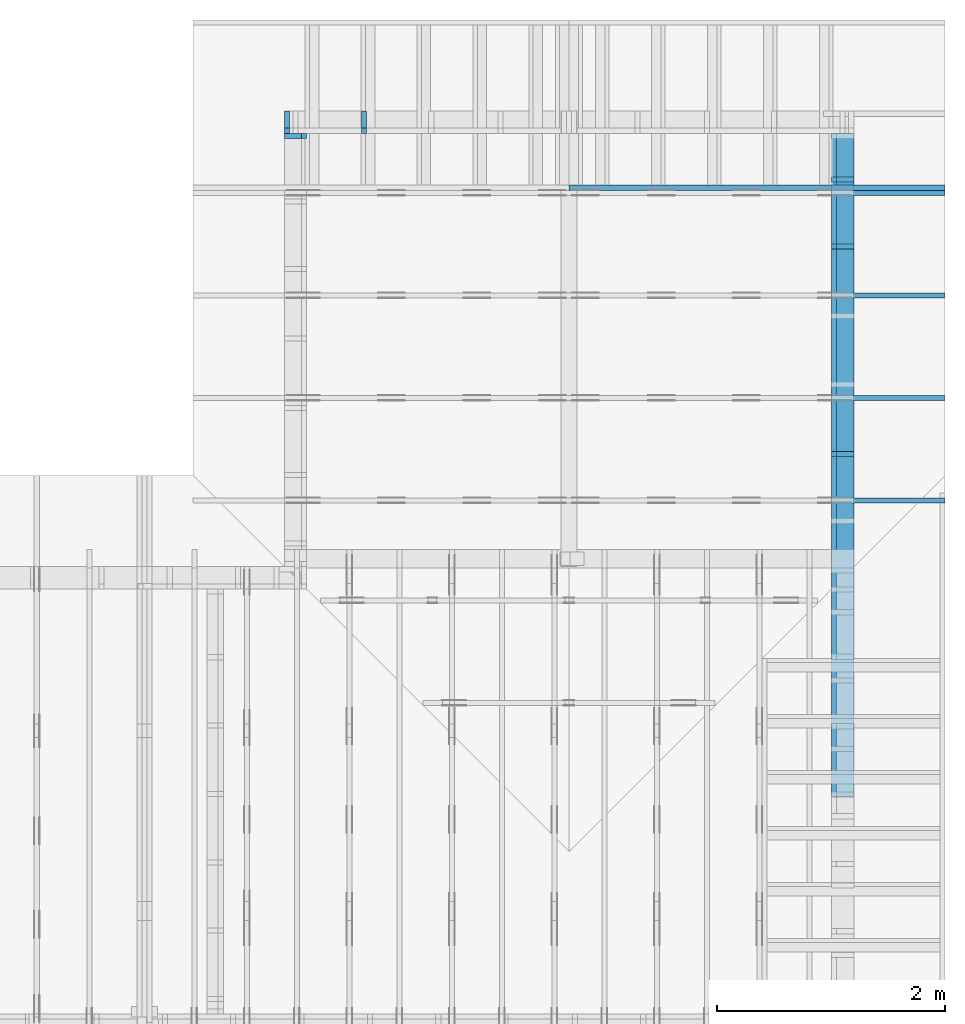
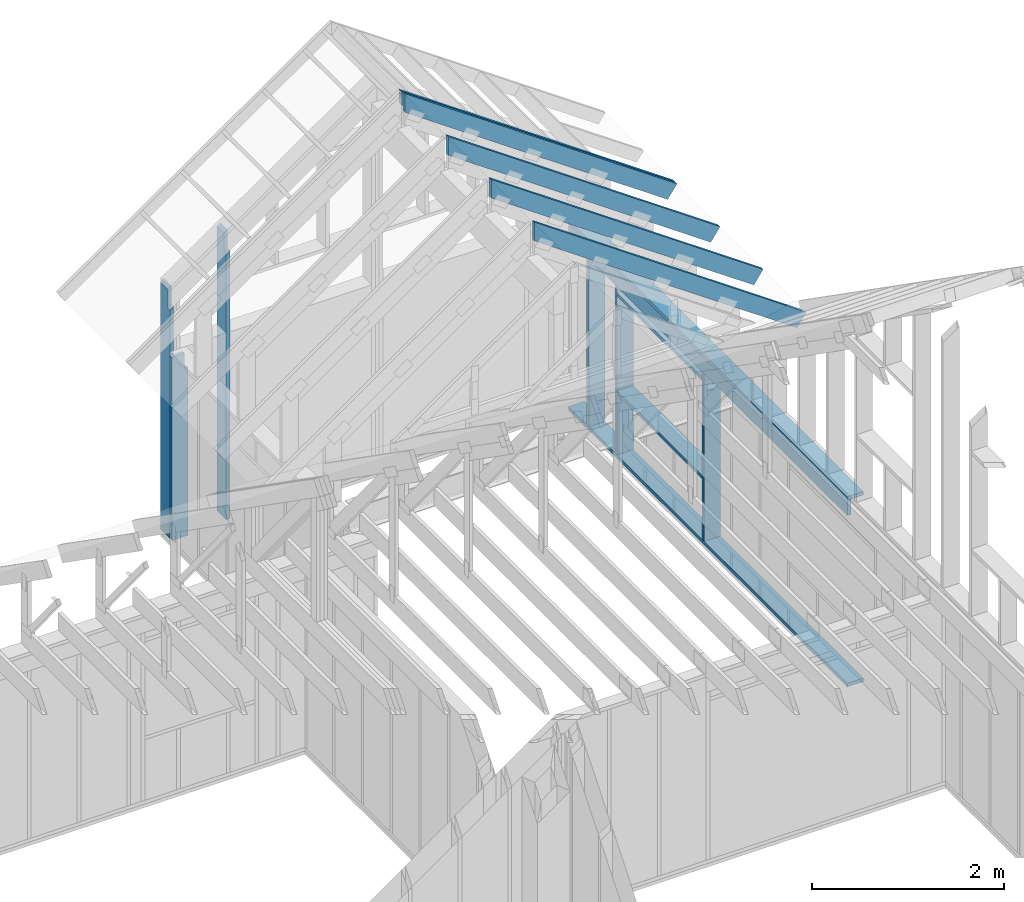
# One storey, part 33 of 70: 16 members, 8 elements without a shape of their own.
"""IFC2X3 building model written with IfcOpenShell, lengths in millimetres."""

from ifc_helpers import new_model, si_unit, frame, origin, origin_with_axes, origin_2d, place, context, project, spatial, faceted_brep, element, aggregate, save


model = new_model("IFC2X3")

# Units and contexts
model_context = context("Model", 3, precision=1e-05, world=origin())
plan_context = context("Plan", 2, precision=1e-05, world=origin_2d())
ifc_project = project(units=[si_unit("LENGTHUNIT", "METRE", prefix="MILLI"), si_unit("AREAUNIT", "SQUARE_METRE"), si_unit("VOLUMEUNIT", "CUBIC_METRE"), si_unit("SOLIDANGLEUNIT", "STERADIAN"), si_unit("PLANEANGLEUNIT", "RADIAN"), si_unit("MASSUNIT", "GRAM"), si_unit("TIMEUNIT", "SECOND"), si_unit("THERMODYNAMICTEMPERATUREUNIT", "DEGREE_CELSIUS"), si_unit("LUMINOUSINTENSITYUNIT", "LUMEN")], contexts=[model_context, plan_context])

# Site, building, storey
site_placement = place(None, origin_with_axes())
site = spatial("IfcSite", under=ifc_project, at=site_placement, CompositionType="ELEMENT")
building_placement = place(site_placement, origin_with_axes())
building = spatial("IfcBuilding", under=site, at=building_placement, Name="Layout 1", CompositionType="ELEMENT")
storey_placement = place(building_placement, origin_with_axes())
storey = spatial("IfcBuildingStorey", under=building, at=storey_placement, Name="Storey 1", CompositionType="ELEMENT", Elevation=0.0)

# Assembly, member
assembly_1_placement = place(storey_placement, frame((7000.0, 11805.0, -2470.0), z_axis=(-1.0, 1.836909530733566e-16, 6.123031769111886e-17), x_axis=(-1.836909530733566e-16, -1.0, 0.0)))
assembly_1 = element("IfcElementAssembly", 1, at=assembly_1_placement, inside=storey, Name="VE1", AssemblyPlace="FACTORY", PredefinedType="NOTDEFINED")
member_1_placement = place(assembly_1_placement, frame((45.00000000186265, 90.00000000000045, -195.00000000000003), z_axis=(0.0, 0.0, 1.0), x_axis=(6.123031769111886e-17, 1.0, 0.0)))
member_1 = element("IfcMember", 2, at=member_1_placement, Name="S11", context=model_context, shape_type="Brep", body=[
    faceted_brep([(2139.999999998137, 45.00000000170723, 2.842170943040401e-14), (2139.999999998137, 45.00000000170723, 45.00000000000003), (2139.999999998137, 1.7072281366381503e-09, 45.00000000000003), (2139.999999998137, 1.7072281366381503e-09, 2.842170943040401e-14), (2139.999999998137, 45.00000000170723, 45.00000000000029), (2334.9999999999995, 45.00000000170723, 45.00000000000031), (2334.9999999999995, 1.7072281366381503e-09, 45.00000000000031), (2139.999999998137, 1.7072281366381503e-09, 45.00000000000029), (-1.0655730319954681e-46, 45.000000001862794, 2.842170943040401e-14), (-7.310846018882921e-31, 45.00000000186278, 195.00000000000003), (2334.9999999999995, 45.00000000186264, 195.00000000000003), (2334.9999999999995, 45.000000001862645, 45.00000000000003), (2139.999999998137, 45.00000000186266, 45.00000000000003), (2139.999999998137, 45.00000000186267, 2.8421709430404e-14), (0.0, 45.00000000000001, 2.842170943040401e-14), (2139.999999998137, 45.00000000000001, 2.904874691481646e-13), (2139.999999998137, 1.7072281366381503e-09, 2.904874691481646e-13), (0.0, 1.7072281366381503e-09, 2.842170943040401e-14), (0.0, 0.0, 0.0), (1.193991194976818e-14, -1.4621692037765842e-30, 195.00000000000003), (1.745064054196888e-14, 45.000000000000014, 195.00000000000003), (5.510728592200699e-15, 45.000000000000014, -3.37423662409981e-31), (2334.9999999999995, 1.7068019736270201e-09, 45.00000000000003), (2334.9999999999995, 1.7068111581746738e-09, 195.00000000000003), (2.1932538056648764e-30, 1.7072400765501e-09, 195.00000000000003), (3.1967190959864043e-46, 1.7072281366381503e-09, 2.842170943040401e-14), (2139.999999998137, 1.7068350379985737e-09, 2.842170943040403e-14), (2139.999999998137, 1.7068377933628698e-09, 45.00000000000003), (2334.9999999999995, 45.0000000018628, 45.00000000000003), (2334.9999999999995, 45.0000000018628, 195.00000000000003), (2334.9999999999995, 1.8628014686328243e-09, 195.00000000000003), (2334.9999999999995, 1.8628014686328243e-09, 45.00000000000003), (2334.9999999999995, 45.000000001862794, 195.00000000000003), (0.0, 45.000000001862794, 195.00000000000003), (0.0, 7.105427357601002e-15, 195.00000000000003), (2334.9999999999995, 7.105427357601002e-15, 195.00000000000003)], [[[0, 1, 2, 3]], [[4, 5, 6, 7]], [[8, 9, 10, 11, 12, 13]], [[14, 15, 16, 17]], [[18, 19, 20, 21]], [[22, 23, 24, 25, 26, 27]], [[28, 29, 30, 31]], [[32, 33, 34, 35]]]),
])
aggregate(assembly_1, [member_1])

# Assembly, members
assembly_2_placement = place(storey_placement, frame((12000.0, 0.0, -2470.0), z_axis=(1.0, -6.123031769111886e-17, 6.123031769111886e-17), x_axis=(6.123031769111886e-17, 1.0, 0.0)))
assembly_2 = element("IfcElementAssembly", 3, at=assembly_2_placement, inside=storey, Name="VE5", AssemblyPlace="FACTORY", PredefinedType="NOTDEFINED")
member_2_placement = place(assembly_2_placement, frame((5980.0, 2425.0, -195.0), z_axis=(0.0, 0.0, 1.0), x_axis=(1.0, 0.0, 0.0)))
member_2 = element("IfcMember", 4, at=member_2_placement, Name="P4", context=model_context, shape_type="Brep", body=[
    faceted_brep([(5825.0, 45.0, 195.0), (0.0, 45.0, 195.0), (0.0, 0.0, 195.0), (5825.0, 0.0, 195.0), (0.0, 45.0, 0.0), (5825.0, 45.0, 7.133332011015348e-13), (5825.0, 0.0, 7.133332011015348e-13), (0.0, 0.0, 0.0), (0.0, 0.0, 0.0), (1.1939911949768178e-14, -1.462169203776584e-30, 195.0), (1.7450640541968876e-14, 45.0, 195.0), (5.510728592200698e-15, 45.0, -3.3742366240998092e-31), (5825.0, -1.0699998016523021e-12, 6.551642778460463e-29), (5825.0, -1.058059889702534e-12, 195.0), (2.193253805664876e-30, 1.1939911949768178e-14, 195.0), (0.0, 0.0, 0.0), (5825.0, 45.0, 0.0), (5825.0, 45.0, 195.0), (5825.0, 0.0, 195.0), (5825.0, 0.0, 0.0), (0.0, 45.0, 0.0), (-7.31084601888292e-31, 44.999999999999986, 195.0), (5825.0, 44.99999999999963, 195.0), (5825.0, 44.999999999999645, -2.1693674893577825e-29)], [[[0, 1, 2, 3]], [[4, 5, 6, 7]], [[8, 9, 10, 11]], [[12, 13, 14, 15]], [[16, 17, 18, 19]], [[20, 21, 22, 23]]]),
])
member_3_placement = place(assembly_2_placement, frame((11805.0, 90.0, -195.0), z_axis=(0.0, 0.0, 1.0), x_axis=(-1.0, 1.2246063538223773e-16, 0.0)))
member_3 = element("IfcMember", 5, at=member_3_placement, Name="P4", context=model_context, shape_type="Brep", body=[
    faceted_brep([(5825.0, 45.00000000000072, 195.0), (0.0, 45.00000000000072, 195.0), (0.0, 0.0, 195.0), (5825.0, 0.0, 195.0), (0.0, 45.00000000000072, 0.0), (5825.0, 45.00000000000072, 7.133332011015348e-13), (5825.0, 0.0, 7.133332011015348e-13), (0.0, 0.0, 0.0), (0.0, 0.0, 0.0), (1.1939911949768178e-14, -1.462169203776584e-30, 195.0), (1.7450640541968876e-14, 45.00000000000001, 195.0), (5.5107285922006985e-15, 45.00000000000001, -3.3742366240998097e-31), (5825.0, -1.0699998016523021e-12, 1.0902318522831229e-28), (5825.0, -1.058059889702534e-12, 195.0), (2.193253805664876e-30, 1.1939911949768178e-14, 195.0), (0.0, 0.0, 0.0), (5825.0, 45.00000000000072, 0.0), (5825.0, 45.00000000000072, 195.0), (5825.0, 7.105427357601002e-13, 195.0), (5825.0, 7.105427357601002e-13, 0.0), (0.0, 45.00000000000001, 0.0), (1.5777218104420236e-30, 44.99999999999999, 195.0), (5825.0, 45.00000000000093, 195.0), (5825.0, 45.000000000000945, 1.3805065841367707e-29)], [[[0, 1, 2, 3]], [[4, 5, 6, 7]], [[8, 9, 10, 11]], [[12, 13, 14, 15]], [[16, 17, 18, 19]], [[20, 21, 22, 23]]]),
])
member_4_placement = place(assembly_2_placement, frame((5980.0, 2230.0, -195.0), z_axis=(0.0, 0.0, 1.0), x_axis=(1.0, 0.0, 0.0)))
member_4 = element("IfcMember", 6, at=member_4_placement, Name="L3", context=model_context, shape_type="Brep", body=[
    faceted_brep([(5825.0, 195.0, 45.0), (0.0, 195.0, 45.0), (0.0, 0.0, 45.0), (5825.0, 0.0, 45.0), (0.0, 195.0, 0.0), (5825.0, 195.0, 7.133332011015348e-13), (5825.0, 0.0, 7.133332011015348e-13), (0.0, 0.0, 0.0), (0.0, 0.0, 0.0), (2.755364296100349e-15, -3.3742366240998092e-31, 45.0), (2.6635188195636705e-14, 195.0, 45.0), (2.3879823899536357e-14, 195.0, -1.462169203776584e-30), (5825.0, -1.0699998016523021e-12, 6.551642778460463e-29), (5825.0, -1.0672444373562018e-12, 45.0), (5.061354936149714e-31, 2.755364296100349e-15, 45.0), (0.0, 0.0, 0.0), (5825.0, 195.0, 0.0), (5825.0, 195.0, 45.0), (5825.0, 0.0, 45.0), (5825.0, 0.0, 0.0), (0.0, 195.0, 0.0), (-1.6871183120499046e-31, 195.0, 45.0), (5825.0, 194.99999999999963, 45.0), (5825.0, 194.99999999999963, -2.208810534618833e-29)], [[[0, 1, 2, 3]], [[4, 5, 6, 7]], [[8, 9, 10, 11]], [[12, 13, 14, 15]], [[16, 17, 18, 19]], [[20, 21, 22, 23]]]),
])
member_5_placement = place(assembly_2_placement, frame((11377.500000001819, 2425.0, -195.0), z_axis=(0.0, 0.0, 1.0), x_axis=(-1.836909530733566e-16, -1.0, 0.0)))
member_5 = element("IfcMember", 7, at=member_5_placement, Name="S11", context=model_context, shape_type="Brep", body=[
    faceted_brep([(0.0, 45.00000000001455, 45.0), (195.00000000186265, 45.00000000001455, 45.00000000000002), (195.00000000186265, 0.0, 45.00000000000002), (0.0, 0.0, 45.0), (195.00000000186265, 1.8189894035458565e-12, 0.0), (195.00000000186265, 1.8189894035458565e-12, 45.0), (195.00000000186265, 45.00000000001273, 45.0), (195.00000000186265, 45.00000000001273, 0.0), (2.755364296100349e-15, -3.3742366240998092e-31, 45.0), (1.193991194976818e-14, -1.4621692037765842e-30, 195.00000000000003), (1.745064054197066e-14, 45.00000000001455, 195.00000000000003), (8.26609288830283e-15, 45.00000000001455, 45.0), (2335.0, -4.2891837542628763e-13, 2.626280839091018e-29), (2335.0, -4.1697846347651946e-13, 195.0), (2.193253805664876e-30, 1.1939911949768178e-14, 195.0), (5.061354936149714e-31, 2.755364296100349e-15, 45.0), (195.00000000186265, -3.306437155354634e-14, 45.0), (195.00000000186265, -3.5819735849646686e-14, 2.193253805685826e-30), (-1.6871183120499046e-31, 45.00000000001273, 45.0), (-7.31084601888292e-31, 45.00000000001272, 195.0), (2335.0, 45.00000000001258, 195.0), (2335.0, 45.00000000001259, -8.67746995743113e-30), (195.00000000186265, 45.00000000001272, -7.888609052210118e-31), (195.00000000186265, 45.00000000001272, 45.0), (2335.0, 45.0, 2.842170943040401e-14), (2335.0, 45.0, 195.0), (2335.0, 1.4551915228366852e-11, 195.0), (2335.0, 1.4551915228366852e-11, 0.0), (2335.0, 45.0, 195.0), (0.0, 45.0, 195.0), (0.0, 0.0, 195.0), (2335.0, 0.0, 195.0), (195.00000000186265, 45.00000000001273, 2.3879823899764457e-14), (2335.0, 45.00000000001273, 2.859455836175251e-13), (2335.0, 1.4551915228366852e-11, 2.859455836175251e-13), (195.00000000186265, 1.4551915228366852e-11, 2.3879823899764457e-14)], [[[0, 1, 2, 3]], [[4, 5, 6, 7]], [[8, 9, 10, 11]], [[12, 13, 14, 15, 16, 17]], [[18, 19, 20, 21, 22, 23]], [[24, 25, 26, 27]], [[28, 29, 30, 31]], [[32, 33, 34, 35]]]),
])
member_6_placement = place(assembly_2_placement, frame((8967.500000003653, 2425.0, -195.00000000000003), z_axis=(0.0, 0.0, 1.0), x_axis=(-1.836909530733566e-16, -1.0, 0.0)))
member_6 = element("IfcMember", 8, at=member_6_placement, Name="S11", context=model_context, shape_type="Brep", body=[
    faceted_brep([(0.0, 45.00000000001455, 45.00000000000003), (195.00000000186265, 45.00000000001455, 45.00000000000005), (195.00000000186265, 1.4551915228366852e-11, 45.00000000000005), (0.0, 1.4551915228366852e-11, 45.00000000000003), (195.00000000186265, 1.2732925824820995e-11, 2.842170943040401e-14), (195.00000000186265, 1.2732925824820995e-11, 45.00000000000003), (195.00000000186265, 45.00000000001273, 45.00000000000003), (195.00000000186265, 45.00000000001273, 2.842170943040401e-14), (2.7553642961021324e-15, 1.4551915228366852e-11, 45.00000000000003), (1.1939911949769961e-14, 1.4551915228366852e-11, 195.00000000000003), (1.745064054197066e-14, 45.00000000001455, 195.00000000000003), (8.26609288830283e-15, 45.00000000001455, 45.00000000000003), (2335.0, 1.4122996852940564e-11, 2.842170943040403e-14), (2335.0, 1.4134936764890332e-11, 195.00000000000003), (2.1932538056648764e-30, 1.456385514031662e-11, 195.00000000000003), (5.061354936149717e-31, 1.4554670592662952e-11, 45.00000000000003), (195.00000000186265, 1.4518850856813305e-11, 45.00000000000003), (195.00000000186265, 1.4516095492517205e-11, 2.8421709430404014e-14), (-1.6871183120499057e-31, 45.00000000001273, 45.00000000000003), (-7.310846018882921e-31, 45.00000000001272, 195.00000000000003), (2335.0, 45.00000000001258, 195.00000000000003), (2335.0, 45.00000000001259, 2.8421709430403998e-14), (195.00000000186265, 45.00000000001272, 2.842170943040401e-14), (195.00000000186265, 45.00000000001272, 45.00000000000003), (2335.0, 45.0, 0.0), (2335.0, 45.0, 195.00000000000003), (2335.0, 0.0, 195.00000000000003), (2335.0, 0.0, 0.0), (2335.0, 45.0, 195.00000000000003), (0.0, 45.0, 195.00000000000003), (0.0, 1.4551915228366852e-11, 195.00000000000003), (2335.0, 1.4551915228366852e-11, 195.00000000000003), (195.00000000186265, 45.00000000001273, 5.2301533330168465e-14), (2335.0, 45.00000000001273, 3.143672930479291e-13), (2335.0, 0.0, 3.143672930479291e-13), (195.00000000186265, 0.0, 5.2301533330168465e-14)], [[[0, 1, 2, 3]], [[4, 5, 6, 7]], [[8, 9, 10, 11]], [[12, 13, 14, 15, 16, 17]], [[18, 19, 20, 21, 22, 23]], [[24, 25, 26, 27]], [[28, 29, 30, 31]], [[32, 33, 34, 35]]]),
])
member_7_placement = place(assembly_2_placement, frame((10787.500000003653, 2425.0, -195.00000000000003), z_axis=(0.0, 0.0, 1.0), x_axis=(-1.836909530733566e-16, -1.0, 0.0)))
member_7 = element("IfcMember", 9, at=member_7_placement, Name="S11", context=model_context, shape_type="Brep", body=[
    faceted_brep([(0.0, 45.0, 45.00000000000003), (195.00000000186265, 45.0, 45.00000000000005), (195.00000000186265, 0.0, 45.00000000000005), (0.0, 0.0, 45.00000000000003), (195.00000000186265, -2.1311460639909362e-46, 2.842170943040401e-14), (195.00000000186265, -3.3742366240998114e-31, 45.00000000000003), (195.00000000186265, 45.0, 45.00000000000003), (195.00000000186265, 45.0, 2.842170943040401e-14), (2.7553642961003504e-15, -3.3742366240998114e-31, 45.00000000000003), (1.193991194976818e-14, -1.4621692037765842e-30, 195.00000000000003), (1.7450640541968876e-14, 45.0, 195.00000000000003), (8.266092888301048e-15, 45.0, 45.00000000000003), (2335.0, -4.2891837542628763e-13, 2.842170943040403e-14), (2335.0, -4.1697846347651946e-13, 195.00000000000003), (2.1932538056648764e-30, 1.193991194976818e-14, 195.00000000000003), (5.061354936149717e-31, 2.7553642961003504e-15, 45.00000000000003), (195.00000000186265, -3.306437155354634e-14, 45.00000000000003), (195.00000000186265, -3.5819735849646686e-14, 2.842170943040401e-14), (-1.6871183120499057e-31, 45.0, 45.00000000000003), (-7.310846018882921e-31, 44.999999999999986, 195.00000000000003), (2335.0, 44.999999999999844, 195.00000000000003), (2335.0, 44.99999999999986, 2.8421709430403998e-14), (195.00000000186265, 44.999999999999986, 2.842170943040401e-14), (195.00000000186265, 44.999999999999986, 45.00000000000003), (2335.0, 45.0, 0.0), (2335.0, 45.0, 195.00000000000003), (2335.0, 0.0, 195.00000000000003), (2335.0, 0.0, 0.0), (2335.0, 45.0, 195.00000000000003), (0.0, 45.0, 195.00000000000003), (0.0, 0.0, 195.00000000000003), (2335.0, 0.0, 195.00000000000003), (195.00000000186265, 45.0, 5.2301533330168465e-14), (2335.0, 45.0, 3.143672930479291e-13), (2335.0, 0.0, 3.143672930479291e-13), (195.00000000186265, 0.0, 5.2301533330168465e-14)], [[[0, 1, 2, 3]], [[4, 5, 6, 7]], [[8, 9, 10, 11]], [[12, 13, 14, 15, 16, 17]], [[18, 19, 20, 21, 22, 23]], [[24, 25, 26, 27]], [[28, 29, 30, 31]], [[32, 33, 34, 35]]]),
])
member_8_placement = place(assembly_2_placement, frame((10787.500000001819, 2154.9999999987776, -195.0), z_axis=(0.0, 0.0, 1.0), x_axis=(-1.0, 1.2246063538223773e-16, 0.0)))
member_8 = element("IfcMember", 10, at=member_8_placement, Name="S17", context=model_context, shape_type="Brep", body=[
    faceted_brep([(1775.0, 45.00000000001501, 195.0), (0.0, 45.00000000001501, 195.0), (0.0, 0.0, 195.0), (1775.0, 0.0, 195.0), (0.0, 45.00000000001501, 0.0), (1775.0, 45.00000000001501, 2.1736762780347196e-13), (1775.0, 0.0, 2.1736762780347196e-13), (0.0, 0.0, 0.0), (0.0, 0.0, 0.0), (1.1939911949768178e-14, -1.462169203776584e-30, 195.0), (1.745064054197066e-14, 45.00000000001455, 195.0), (5.51072859220248e-15, 45.00000000001455, -3.3742366241009005e-31), (1775.0, -3.2605144170520794e-13, 4.7808558123230106e-29), (1775.0, -3.1411152975543977e-13, 195.0), (2.193253805664876e-30, 1.1939911949768178e-14, 195.0), (0.0, 0.0, 0.0), (1775.0, 45.00000000001501, 0.0), (1775.0, 45.00000000001501, 195.0), (1775.0, 4.547473508864641e-13, 195.0), (1775.0, 4.547473508864641e-13, 0.0), (0.0, 45.00000000001455, 0.0), (1.5777218104420236e-30, 45.00000000001454, 195.0), (1775.0, 45.00000000001482, 195.0), (1775.0, 45.000000000014836, -1.064962222048366e-29)], [[[0, 1, 2, 3]], [[4, 5, 6, 7]], [[8, 9, 10, 11]], [[12, 13, 14, 15]], [[16, 17, 18, 19]], [[20, 21, 22, 23]]]),
])
member_9_placement = place(assembly_2_placement, frame((9012.500000001819, 863.1713847472129, -195.0), z_axis=(0.0, 0.0, 1.0), x_axis=(1.0, 0.0, 0.0)))
member_9 = element("IfcMember", 11, at=member_9_placement, Name="S17", context=model_context, shape_type="Brep", body=[
    faceted_brep([(1775.0, 45.0, 195.0), (0.0, 45.0, 195.0), (0.0, 0.0, 195.0), (1775.0, 0.0, 195.0), (0.0, 45.0, 0.0), (1775.0, 45.0, 2.1736762780347196e-13), (1775.0, 0.0, 2.1736762780347196e-13), (0.0, 0.0, 0.0), (0.0, 0.0, 0.0), (1.1939911949768178e-14, -1.462169203776584e-30, 195.0), (1.7450640541968876e-14, 45.0, 195.0), (5.510728592200698e-15, 45.0, -3.3742366240998092e-31), (1775.0, -3.2605144170520794e-13, 1.9964233359257205e-29), (1775.0, -3.1411152975543977e-13, 195.0), (2.193253805664876e-30, 1.1939911949768178e-14, 195.0), (0.0, 0.0, 0.0), (1775.0, 45.0, 0.0), (1775.0, 45.0, 195.0), (1775.0, 0.0, 195.0), (1775.0, 0.0, 0.0), (0.0, 45.0, 0.0), (-7.31084601888292e-31, 44.999999999999986, 195.0), (1775.0, 44.99999999999988, 195.0), (1775.0, 44.99999999999989, -6.7053176943786e-30)], [[[0, 1, 2, 3]], [[4, 5, 6, 7]], [[8, 9, 10, 11]], [[12, 13, 14, 15]], [[16, 17, 18, 19]], [[20, 21, 22, 23]]]),
])
aggregate(assembly_2, [member_2, member_3, member_4, member_5, member_6, member_7, member_8, member_9])

assembly_3_placement = place(storey_placement, frame((12000.0, 12000.0, -2470.0), z_axis=(1.2246063538223773e-16, 1.0, 6.123031769111886e-17), x_axis=(-1.0, 1.2246063538223773e-16, 0.0)))
assembly_3 = element("IfcElementAssembly", 12, at=assembly_3_placement, inside=storey, Name="VE6", AssemblyPlace="FACTORY", PredefinedType="NOTDEFINED")
member_10_placement = place(assembly_3_placement, frame((4955.000000000001, 3269.562167353928, -195.00000000000003), z_axis=(0.0, 0.0, 1.0), x_axis=(-1.836909530733566e-16, -1.0, 0.0)))
member_10 = element("IfcMember", 13, at=member_10_placement, Name="S5/", context=model_context, shape_type="Brep", body=[
    faceted_brep([(31.50933921802789, 44.99999999906777, 45.000000000000036), (269.56038402675586, 44.99999999906777, 45.000000000000064), (238.05104480848468, 9.304130799137056e-10, 45.00000000000006), (0.0, 9.304130799137056e-10, 45.00000000000003), (238.05104480838088, 9.331557748737396e-10, 2.8421709430404014e-14), (238.05104480838088, 9.331557748737396e-10, 45.00000000000003), (269.56038402675574, 44.99999999913783, 45.00000000000003), (269.56038402675574, 44.99999999913783, 2.8421709430404014e-14), (3.274287700891955e-11, 9.076749647262186e-10, 45.00000000000003), (3.275040054990594e-11, 9.07669696686106e-10, 195.00000000000003), (31.509339218027897, 44.99999999906776, 195.00000000000003), (31.50933921802789, 44.99999999906777, 45.00000000000003), (3179.562167353928, 9.298290231088283e-10, 2.8421709430404045e-14), (3179.562167353928, 9.298409630207781e-10, 195.00000000000003), (2.1932538056648764e-30, 9.304250198256554e-10, 195.00000000000003), (5.061354936149717e-31, 9.304158352780017e-10, 45.00000000000003), (238.05104480848468, 9.303721074547007e-10, 45.00000000000003), (238.05104480848468, 9.303693520904046e-10, 2.8421709430404014e-14), (31.50933921802789, 44.99999999913779, 45.00000000000003), (31.50933921802789, 44.999999999137785, 195.00000000000003), (3179.562167353928, 44.99999999913759, 195.00000000000003), (3179.562167353928, 44.99999999913761, 2.8421709430403995e-14), (269.56038402675586, 44.999999999137785, 2.8421709430404004e-14), (269.56038402675586, 44.99999999913778, 45.00000000000003), (3179.562167353928, 45.0, 0.0), (3179.562167353928, 45.0, 195.00000000000003), (3179.562167353928, 0.0, 195.00000000000003), (3179.562167353928, 0.0, 0.0), (3179.562167353928, 45.0, 195.00000000000003), (31.50933921802789, 45.0, 195.00000000000003), (0.0, 9.304130799137056e-10, 195.00000000000003), (3179.562167353928, 9.304130799137056e-10, 195.00000000000003), (269.56038402675586, 44.9999999991378, 6.143224533220053e-14), (3179.562167353928, 44.9999999991378, 4.177929126818909e-13), (3179.562167353928, 0.0, 4.177929126818909e-13), (238.05104480848468, 0.0, 5.757359163105658e-14)], [[[0, 1, 2, 3]], [[4, 5, 6, 7]], [[8, 9, 10, 11]], [[12, 13, 14, 15, 16, 17]], [[18, 19, 20, 21, 22, 23]], [[24, 25, 26, 27]], [[28, 29, 30, 31]], [[32, 33, 34, 35]]]),
])
member_11_placement = place(assembly_3_placement, frame((4322.499999999389, 89.99999999999999, -195.00000000000003), z_axis=(0.0, 0.0, 1.0), x_axis=(6.123031769111886e-17, 1.0, 0.0)))
member_11 = element("IfcMember", 14, at=member_11_placement, Name="S2", context=model_context, shape_type="Brep", body=[
    faceted_brep([(3415.9017296841494, 44.99999999999977, 2.842170943040401e-14), (3415.9017296841494, 44.99999999999977, 45.00000000000003), (3384.3923904646467, 1.7053025658242404e-11, 45.00000000000003), (3384.3923904646467, 1.7053025658242404e-11, 2.842170943040401e-14), (3415.901729684149, 45.0, 45.00000000000045), (3653.952774492558, 45.0, 45.000000000000476), (3622.443435273075, 0.0, 45.00000000000047), (3384.3923904646717, 0.0, 45.00000000000044), (-1.0655730319954681e-46, 45.0, 2.842170943040401e-14), (-7.310846018882921e-31, 44.999999999999986, 195.00000000000003), (3653.952774492558, 44.999999999999766, 195.00000000000003), (3653.952774492558, 44.99999999999977, 45.00000000000003), (3415.901729684149, 44.99999999999979, 45.00000000000003), (3415.901729684149, 44.999999999999794, 2.8421709430403995e-14), (0.0, 45.0, 2.842170943040401e-14), (3415.901729684149, 45.0, 4.4673520565080976e-13), (3384.3923904646717, 0.0, 4.428765519495181e-13), (1.4210854715202004e-14, 0.0, 2.842170943040401e-14), (1.4210854715202004e-14, 0.0, 0.0), (2.6150766664970182e-14, -1.462169203776584e-30, 195.00000000000003), (3.166149525717088e-14, 45.0, 195.00000000000003), (1.97215833074027e-14, 45.0, -1.207558811284134e-30), (3622.443435273075, -6.626547227835347e-13, 45.00000000000003), (3622.443435273075, -6.534701751298669e-13, 195.00000000000003), (1.4210854715202007e-14, 1.1939911949768177e-14, 195.00000000000003), (1.4210854715202004e-14, -8.701351488741532e-31, 2.842170943040401e-14), (3384.3923904646717, -6.216822637786711e-13, 2.8421709430404045e-14), (3384.3923904646717, -6.189268994825708e-13, 45.00000000000003), (3653.952774492578, 44.9999999999859, 45.00000000000003), (3653.952774492578, 44.9999999999859, 195.00000000000003), (3622.443435273074, 4.547473508864641e-13, 195.00000000000003), (3622.443435273074, 4.547473508864641e-13, 45.00000000000003), (3653.952774492558, 45.0, 195.00000000000003), (0.0, 45.0, 195.00000000000003), (1.4210854715202004e-14, 0.0, 195.00000000000003), (3622.443435273075, 0.0, 195.00000000000003)], [[[0, 1, 2, 3]], [[4, 5, 6, 7]], [[8, 9, 10, 11, 12, 13]], [[14, 15, 16, 17]], [[18, 19, 20, 21]], [[22, 23, 24, 25, 26, 27]], [[28, 29, 30, 31]], [[32, 33, 34, 35]]]),
])
aggregate(assembly_3, [member_10, member_11])

# Assembly, member
assembly_4_placement = place(storey_placement, frame((12000.0, 8605.0, 1.3776821480501744e-15), z_axis=(1.2246063538223773e-16, 1.0, 6.123031769111886e-17), x_axis=(-1.0, 1.2246063538223773e-16, 0.0)))
assembly_4 = element("IfcElementAssembly", 15, at=assembly_4_placement, inside=storey, Name="T10", AssemblyPlace="FACTORY", PredefinedType="TRUSS")
member_12_placement = place(assembly_4_placement, frame((-688.1525949112562, 280.0993207951619, -45.00000000000001), z_axis=(0.0, 0.0, 1.0), x_axis=(0.8191520442889921, 0.5735764363510459, 0.0)))
member_12 = element("IfcMember", 16, at=member_12_placement, Name="T11", context=model_context, shape_type="Brep", body=[
    faceted_brep([(4001.088714666729, 195.00000000200953, 45.0), (0.0, 195.00000000200953, 45.0), (3.9256065065274015e-10, 0.0, 45.0), (3864.548244715711, 0.0, 45.0), (0.0, 195.00000000200953, 0.0), (4001.088714666729, 195.00000000200953, 4.899758662187885e-13), (3864.548244715711, 0.0, 4.732550335131975e-13), (3.9256065065274015e-10, 0.0, 4.8073226704999214e-26), (3.9256065065274015e-10, 0.0, 0.0), (3.9256340601703625e-10, 5.5463662745431186e-27, 45.0), (4.1290131103463413e-14, 195.00000000050534, 45.0), (3.8534766807363065e-14, 195.00000000050534, -2.359496013768499e-30), (3864.548244715711, 1.8321961778695714e-09, -1.169569360757028e-30), (3864.548244715711, 1.8321989332338675e-09, 45.0), (3.9256065065274015e-10, 2.755364296102289e-15, 45.0), (3.9256065065274015e-10, 1.9402938235509647e-27, -1.1880480723038727e-43), (4001.0887146667305, 195.00000000200907, 1.1610223602160909e-28), (4001.0887146667305, 195.00000000200907, 45.0), (3864.548244715712, 1.8314949556952342e-09, 45.0), (3864.548244715712, 1.8314949556952342e-09, 8.939158422096953e-29), (0.0, 195.00000000050534, 0.0), (0.0, 195.00000000050534, 45.0), (4001.088714666729, 195.00000000201007, 45.0), (4001.088714666729, 195.00000000201007, 3.470987982972452e-29)], [[[0, 1, 2, 3]], [[4, 5, 6, 7]], [[8, 9, 10, 11]], [[12, 13, 14, 15]], [[16, 17, 18, 19]], [[20, 21, 22, 23]]]),
])
aggregate(assembly_4, [member_12])

assembly_5_placement = place(storey_placement, frame((12000.0, 9505.0, 1.3776821480501744e-15), z_axis=(1.2246063538223773e-16, 1.0, 6.123031769111886e-17), x_axis=(-1.0, 1.2246063538223773e-16, 0.0)))
assembly_5 = element("IfcElementAssembly", 17, at=assembly_5_placement, inside=storey, Name="T10", AssemblyPlace="FACTORY", PredefinedType="TRUSS")
member_13_placement = place(assembly_5_placement, frame((-688.1525949112562, 280.0993207951619, -45.00000000000001), z_axis=(0.0, 0.0, 1.0), x_axis=(0.8191520442889921, 0.5735764363510459, 0.0)))
member_13 = element("IfcMember", 18, at=member_13_placement, Name="T11", context=model_context, shape_type="Brep", body=[
    faceted_brep([(4001.088714666729, 195.00000000200953, 45.0), (0.0, 195.00000000200953, 45.0), (3.9256065065274015e-10, 0.0, 45.0), (3864.548244715711, 0.0, 45.0), (0.0, 195.00000000200953, 0.0), (4001.088714666729, 195.00000000200953, 4.899758662187885e-13), (3864.548244715711, 0.0, 4.732550335131975e-13), (3.9256065065274015e-10, 0.0, 4.8073226704999214e-26), (3.9256065065274015e-10, 0.0, 0.0), (3.9256340601703625e-10, 5.5463662745431186e-27, 45.0), (4.1290131103463413e-14, 195.00000000050534, 45.0), (3.8534766807363065e-14, 195.00000000050534, -2.359496013768499e-30), (3864.548244715711, 1.8321961778695714e-09, -1.169569360757028e-30), (3864.548244715711, 1.8321989332338675e-09, 45.0), (3.9256065065274015e-10, 2.755364296102289e-15, 45.0), (3.9256065065274015e-10, 1.9402938235509647e-27, -1.1880480723038727e-43), (4001.0887146667305, 195.00000000200907, 1.1610223602160909e-28), (4001.0887146667305, 195.00000000200907, 45.0), (3864.548244715712, 1.8314949556952342e-09, 45.0), (3864.548244715712, 1.8314949556952342e-09, 8.939158422096953e-29), (0.0, 195.00000000050534, 0.0), (0.0, 195.00000000050534, 45.0), (4001.088714666729, 195.00000000201007, 45.0), (4001.088714666729, 195.00000000201007, 3.470987982972452e-29)], [[[0, 1, 2, 3]], [[4, 5, 6, 7]], [[8, 9, 10, 11]], [[12, 13, 14, 15]], [[16, 17, 18, 19]], [[20, 21, 22, 23]]]),
])
aggregate(assembly_5, [member_13])

assembly_6_placement = place(storey_placement, frame((12000.0, 10405.0, 1.3776821480501744e-15), z_axis=(1.2246063538223773e-16, 1.0, 6.123031769111886e-17), x_axis=(-1.0, 1.2246063538223773e-16, 0.0)))
assembly_6 = element("IfcElementAssembly", 19, at=assembly_6_placement, inside=storey, Name="T10", AssemblyPlace="FACTORY", PredefinedType="TRUSS")
member_14_placement = place(assembly_6_placement, frame((-688.1525949112562, 280.0993207951619, -45.00000000000001), z_axis=(0.0, 0.0, 1.0), x_axis=(0.8191520442889921, 0.5735764363510459, 0.0)))
member_14 = element("IfcMember", 20, at=member_14_placement, Name="T11", context=model_context, shape_type="Brep", body=[
    faceted_brep([(4001.088714666729, 195.00000000200953, 45.0), (0.0, 195.00000000200953, 45.0), (3.9256065065274015e-10, 0.0, 45.0), (3864.548244715711, 0.0, 45.0), (0.0, 195.00000000200953, 0.0), (4001.088714666729, 195.00000000200953, 4.899758662187885e-13), (3864.548244715711, 0.0, 4.732550335131975e-13), (3.9256065065274015e-10, 0.0, 4.8073226704999214e-26), (3.9256065065274015e-10, 0.0, 0.0), (3.9256340601703625e-10, 5.5463662745431186e-27, 45.0), (4.1290131103463413e-14, 195.00000000050534, 45.0), (3.8534766807363065e-14, 195.00000000050534, -2.359496013768499e-30), (3864.548244715711, 1.8321961778695714e-09, -1.169569360757028e-30), (3864.548244715711, 1.8321989332338675e-09, 45.0), (3.9256065065274015e-10, 2.755364296102289e-15, 45.0), (3.9256065065274015e-10, 1.9402938235509647e-27, -1.1880480723038727e-43), (4001.0887146667305, 195.00000000200907, 1.1610223602160909e-28), (4001.0887146667305, 195.00000000200907, 45.0), (3864.548244715712, 1.8314949556952342e-09, 45.0), (3864.548244715712, 1.8314949556952342e-09, 8.939158422096953e-29), (0.0, 195.00000000050534, 0.0), (0.0, 195.00000000050534, 45.0), (4001.088714666729, 195.00000000201007, 45.0), (4001.088714666729, 195.00000000201007, 3.470987982972452e-29)], [[[0, 1, 2, 3]], [[4, 5, 6, 7]], [[8, 9, 10, 11]], [[12, 13, 14, 15]], [[16, 17, 18, 19]], [[20, 21, 22, 23]]]),
])
aggregate(assembly_6, [member_14])

assembly_7_placement = place(storey_placement, frame((12000.0, 11305.0, 1.3776821480501744e-15), z_axis=(1.2246063538223773e-16, 1.0, 6.123031769111886e-17), x_axis=(-1.0, 1.2246063538223773e-16, 0.0)))
assembly_7 = element("IfcElementAssembly", 21, at=assembly_7_placement, inside=storey, Name="T10", AssemblyPlace="FACTORY", PredefinedType="TRUSS")
member_15_placement = place(assembly_7_placement, frame((-688.1525949112562, 280.0993207951619, -45.00000000000001), z_axis=(0.0, 0.0, 1.0), x_axis=(0.8191520442889921, 0.5735764363510459, 0.0)))
member_15 = element("IfcMember", 22, at=member_15_placement, Name="T11", context=model_context, shape_type="Brep", body=[
    faceted_brep([(4001.088714666729, 195.00000000200953, 45.0), (0.0, 195.00000000200953, 45.0), (3.9256065065274015e-10, 0.0, 45.0), (3864.548244715711, 0.0, 45.0), (0.0, 195.00000000200953, 0.0), (4001.088714666729, 195.00000000200953, 4.899758662187885e-13), (3864.548244715711, 0.0, 4.732550335131975e-13), (3.9256065065274015e-10, 0.0, 4.8073226704999214e-26), (3.9256065065274015e-10, 0.0, 0.0), (3.9256340601703625e-10, 5.5463662745431186e-27, 45.0), (4.1290131103463413e-14, 195.00000000050534, 45.0), (3.8534766807363065e-14, 195.00000000050534, -2.359496013768499e-30), (3864.548244715711, 1.8321961778695714e-09, -1.169569360757028e-30), (3864.548244715711, 1.8321989332338675e-09, 45.0), (3.9256065065274015e-10, 2.755364296102289e-15, 45.0), (3.9256065065274015e-10, 1.9402938235509647e-27, -1.1880480723038727e-43), (4001.0887146667305, 195.00000000200907, 1.1610223602160909e-28), (4001.0887146667305, 195.00000000200907, 45.0), (3864.548244715712, 1.8314949556952342e-09, 45.0), (3864.548244715712, 1.8314949556952342e-09, 8.939158422096953e-29), (0.0, 195.00000000050534, 0.0), (0.0, 195.00000000050534, 45.0), (4001.088714666729, 195.00000000201007, 45.0), (4001.088714666729, 195.00000000201007, 3.470987982972452e-29)], [[[0, 1, 2, 3]], [[4, 5, 6, 7]], [[8, 9, 10, 11]], [[12, 13, 14, 15]], [[16, 17, 18, 19]], [[20, 21, 22, 23]]]),
])
aggregate(assembly_7, [member_15])

assembly_8_placement = place(storey_placement, frame((12800.0, 12799.999999999998, 439.8339694322314), z_axis=(0.5735764363510458, -3.1388626346160497e-16, 0.8191520442889919), x_axis=(-0.8191520442889919, 4.2897019649573644e-16, 0.5735764363510458)))
assembly_8 = element("IfcElementAssembly", 23, at=assembly_8_placement, inside=storey, Name="gs5", AssemblyPlace="FACTORY", PredefinedType="TRUSS")
member_16_placement = place(assembly_8_placement, frame((-1.7470297232624795e-10, 1450.0, -145.0), z_axis=(0.0, 0.0, 1.0), x_axis=(1.0, 0.0, 0.0)))
member_16 = element("IfcMember", 24, at=member_16_placement, Name="T4", context=model_context, shape_type="Brep", body=[
    faceted_brep([(3927.0260498721154, 45.0, 9.799805411603302e-11), (4028.556142912984, 45.0, 144.99999999999932), (4028.556142912984, 0.0, 144.99999999999932), (3927.0260498721154, 0.0, 9.799805411603302e-11), (7.998958584573299e-14, 45.0, 0.0), (7.998958584573299e-14, 44.99999999999999, 145.0), (4028.5561429129834, 44.999999999999744, 145.0), (3927.026049872255, 44.99999999999976, -1.4593926746588718e-29), (7.998958584573299e-14, 45.0, 9.795575506630512e-30), (3927.026049872255, 45.0, 4.809061052299555e-13), (3927.0260498722546, 0.0, 4.809061052299554e-13), (7.998958584573299e-14, 0.0, 9.795575506630512e-30), (8.851479170560669e-14, 0.0, 2.8421709430404004e-14), (1.61786123199078e-13, 1.5372218472799534e-28, 145.0), (6.73767795750146e-14, 45.0, 145.0), (-5.894551918456712e-15, 45.0, 2.978632190501519e-30), (4028.5561429129834, -7.31130921335999e-13, 145.0), (7.998958584573299e-14, 8.878396065212221e-15, 145.0), (7.998958584573299e-14, -1.469336325994577e-29, 8.996793003574933e-46), (3927.0260498722546, -7.213591578449333e-13, 4.4169050404243217e-29), (4028.5561429129834, 45.0, 145.0), (7.998958584573299e-14, 45.0, 145.0), (7.998958584573299e-14, 0.0, 145.0), (4028.5561429129834, 0.0, 145.0)], [[[0, 1, 2, 3]], [[4, 5, 6, 7]], [[8, 9, 10, 11]], [[12, 13, 14, 15]], [[16, 17, 18, 19]], [[20, 21, 22, 23]]]),
])
aggregate(assembly_8, [member_16])

save(model, "model.ifc")
